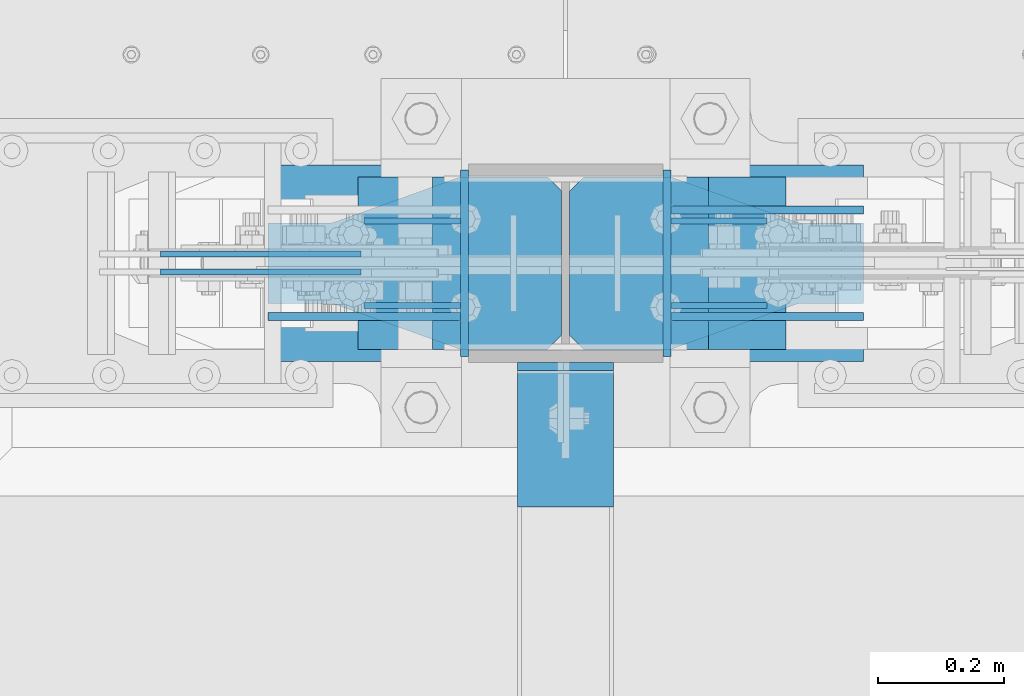
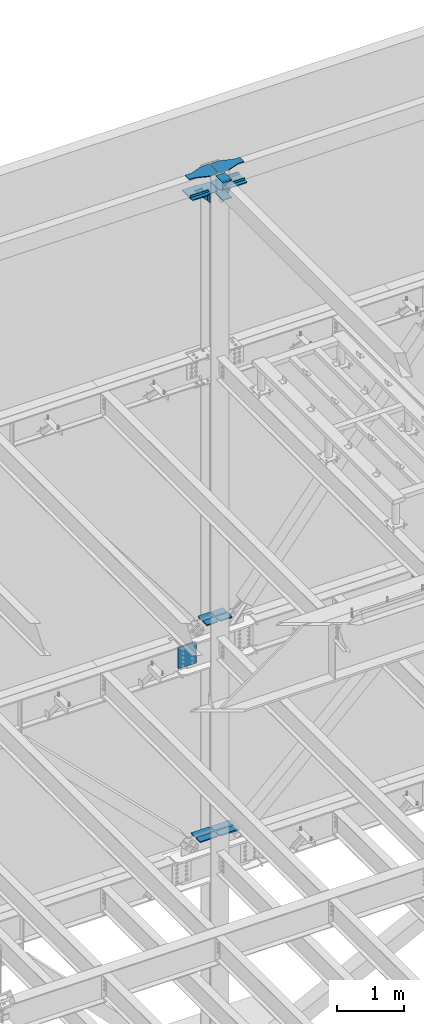
# One storey, part 885 of 1179: 25 beams, 9 elements without a shape of their own.
"""IFC2X3 building model written with IfcOpenShell, lengths in millimetres."""

from ifc_helpers import new_model, si_unit, frame, origin_with_axes, place, context, subcontext, project, spatial, faceted_brep, material, type_object, element, aggregate, save


model = new_model("IFC2X3")

# Units and contexts
model_context = context("Model", 3, precision=1e-05, world=origin_with_axes())
body_context = subcontext(model_context, "Body", "Model", "MODEL_VIEW")
ifc_project = project(units=[si_unit("LENGTHUNIT", "METRE", prefix="MILLI"), si_unit("AREAUNIT", "SQUARE_METRE"), si_unit("VOLUMEUNIT", "CUBIC_METRE"), si_unit("MASSUNIT", "GRAM", prefix="KILO"), si_unit("TIMEUNIT", "SECOND"), si_unit("PLANEANGLEUNIT", "RADIAN"), si_unit("SOLIDANGLEUNIT", "STERADIAN"), si_unit("THERMODYNAMICTEMPERATUREUNIT", "DEGREE_CELSIUS"), si_unit("LUMINOUSINTENSITYUNIT", "LUMEN")], contexts=[model_context])

# Site, building, storey
site_placement = place(None, origin_with_axes())
site = spatial("IfcSite", under=ifc_project, at=site_placement, CompositionType="ELEMENT")
building_placement = place(site_placement, origin_with_axes())
building = spatial("IfcBuilding", under=site, at=building_placement, Name="Undefined", CompositionType="ELEMENT")
storey_placement = place(building_placement, origin_with_axes())
storey = spatial("IfcBuildingStorey", under=building, at=storey_placement, Name="Undefined", CompositionType="ELEMENT", Elevation=0.0)

# Assembly, beams
assembly_1_placement = place(storey_placement, origin_with_axes())
assembly_1 = element("IfcElementAssembly", 1, at=assembly_1_placement, inside=storey, Name="COLUMN", AssemblyPlace="NOTDEFINED", PredefinedType="RIGID_FRAME")
ifc_material_1 = material(Name="STEEL/A36")
beam_type_1 = type_object("IfcBeamType", PredefinedType="NOTDEFINED")
beam_1_placement = place(assembly_1_placement, frame((8120.0625, 41346.4375, 16030.575), z_axis=(0.0, 0.0, 1.0), x_axis=(0.0, -1.0, 0.0)))
beam_1 = element("IfcBeam", 2, at=beam_1_placement, type_object=beam_type_1, material=ifc_material_1, Name="PLATE", context=body_context, shape_type="Brep", body=[
    faceted_brep([(-7.27595761418343e-12, 6.35000000000036, -76.1999999999971), (0.0, 6.35000000000036, 76.2000000000044), (295.274999999994, 6.34999999999854, 76.2000000000007), (295.274999999994, 6.34999999999854, -76.2000000000007), (0.0, -6.35000000000036, 76.2000000000044), (295.274999999994, -6.34999999999854, 76.2000000000007), (7.27595761418343e-12, -6.35000000000036, -76.1999999999971), (295.274999999994, -6.34999999999854, -76.2000000000007)], [[[0, 1, 2, 3]], [[1, 4, 5, 2]], [[4, 6, 7, 5]], [[6, 0, 3, 7]], [[5, 7, 3, 2]], [[6, 4, 1, 0]]]),
])
beam_2_placement = place(assembly_1_placement, frame((8440.73750000001, 41051.1625, 16030.575), z_axis=(0.0, 0.0, 1.0), x_axis=(0.0, 1.0, 0.0)))
beam_2 = element("IfcBeam", 3, at=beam_2_placement, type_object=beam_type_1, material=ifc_material_1, Name="PLATE", context=body_context, shape_type="Brep", body=[
    faceted_brep([(-7.27595761418343e-12, 6.35000000000036, -76.1999999999971), (0.0, 6.35000000000036, 76.2000000000044), (295.274999999994, 6.34999999999854, 76.2000000000007), (295.274999999994, 6.34999999999854, -76.2000000000007), (0.0, -6.35000000000036, 76.2000000000044), (295.274999999994, -6.34999999999854, 76.2000000000007), (7.27595761418343e-12, -6.35000000000036, -76.1999999999971), (295.274999999994, -6.34999999999854, -76.2000000000007)], [[[0, 1, 2, 3]], [[1, 4, 5, 2]], [[4, 6, 7, 5]], [[6, 0, 3, 7]], [[5, 7, 3, 2]], [[6, 4, 1, 0]]]),
])
beam_3_placement = place(assembly_1_placement, frame((8280.4, 40813.0375061035, 16116.3), z_axis=(1.0, 0.0, 0.0), x_axis=(0.0, 1.0, 0.0)))
beam_3 = element("IfcBeam", 4, at=beam_3_placement, type_object=beam_type_1, material=ifc_material_1, Name="PLATE", context=body_context, shape_type="Brep", body=[
    faceted_brep([(215.900000000001, 6.35000000000036, 76.2000000000007), (228.599999999999, -6.35000000000036, 76.2000000000007), (228.599999999999, -6.35000000000036, -76.2000000000007), (215.900000000001, 6.35000000000036, -76.2000000000007), (-7.27595761418343e-12, 6.35000000000036, -76.1999999999971), (0.0, 6.35000000000036, 76.2000000000044), (0.0, -6.35000000000036, 76.2000000000044), (7.27595761418343e-12, -6.35000000000036, -76.1999999999971)], [[[0, 1, 2, 3]], [[4, 5, 0, 3]], [[5, 6, 1, 0]], [[6, 7, 2, 1]], [[7, 4, 3, 2]], [[7, 6, 5, 4]]]),
])
beam_4_placement = place(assembly_1_placement, frame((8280.4, 40813.0375059853, 16435.3875), z_axis=(1.0, 0.0, 0.0), x_axis=(0.0, 1.0, 0.0)))
beam_4 = element("IfcBeam", 5, at=beam_4_placement, type_object=beam_type_1, material=ifc_material_1, Name="PLATE", context=body_context, shape_type="Brep", body=[
    faceted_brep([(215.900000000001, 6.35000000000036, 76.2000000000007), (228.599999999999, -6.35000000000036, 76.2000000000007), (228.599999999999, -6.35000000000036, -76.2000000000007), (215.900000000001, 6.35000000000036, -76.2000000000007), (-7.27595761418343e-12, 6.35000000000036, -76.1999999999971), (0.0, 6.35000000000036, 76.2000000000044), (0.0, -6.35000000000036, 76.2000000000044), (7.27595761418343e-12, -6.35000000000036, -76.1999999999971)], [[[0, 1, 2, 3]], [[4, 5, 0, 3]], [[5, 6, 1, 0]], [[6, 7, 2, 1]], [[7, 4, 3, 2]], [[7, 6, 5, 4]]]),
])

# Assembly, beam
assembly_2_placement = place(storey_placement, origin_with_axes())
assembly_2 = element("IfcElementAssembly", 6, at=assembly_2_placement, inside=storey, Name="PLATE", AssemblyPlace="NOTDEFINED", PredefinedType="RIGID_FRAME")
ifc_material_2 = material(Name="STEEL/A572-GR.50")
beam_type_2 = type_object("IfcBeamType", PredefinedType="NOTDEFINED")
beam_5_placement = place(assembly_2_placement, frame((8274.0300674267, 41124.981, 4351.42154734331), z_axis=(0.0, 1.0, 0.0), x_axis=(-1.0, 0.0, 0.0)))
beam_5 = element("IfcBeam", 7, at=beam_5_placement, type_object=beam_type_2, material=ifc_material_2, Name="PLATE", context=body_context, shape_type="Brep", body=[
    faceted_brep([(0.0, 9.52499999999964, -40.4814999999999), (22.2249999999985, 9.52499999999964, -62.7065000000002), (22.2249999999985, -9.52499999999964, -62.7065000000002), (0.0, -9.52499999999964, -40.4814999999999), (0.0, 9.52499999999964, 62.7065000000002), (322.216540172532, 9.52499999999964, 62.7065000000002), (322.216540172532, 9.52499999999964, -62.7065000000002), (0.0, -9.52499999999964, 62.7065000000002), (322.216540172532, -9.52499999999964, 62.7065000000002), (322.216540172532, -9.52499999999964, -62.7065000000002)], [[[0, 1, 2, 3]], [[4, 5, 6, 1, 0]], [[4, 7, 8, 5]], [[9, 8, 7, 3, 2]], [[6, 9, 2, 1]], [[8, 9, 6, 5]], [[7, 4, 0, 3]]]),
])
aggregate(assembly_2, [beam_5])

assembly_3_placement = place(storey_placement, origin_with_axes())
assembly_3 = element("IfcElementAssembly", 8, at=assembly_3_placement, inside=storey, Name="PLATE", AssemblyPlace="NOTDEFINED", PredefinedType="RIGID_FRAME")
beam_6_placement = place(assembly_3_placement, frame((8274.0300674267, 41272.619, 4351.42154734331), z_axis=(0.0, -1.0, 0.0), x_axis=(-1.0, 0.0, 0.0)))
beam_6 = element("IfcBeam", 9, at=beam_6_placement, type_object=beam_type_2, material=ifc_material_2, Name="PLATE", context=body_context, shape_type="Brep", body=[
    faceted_brep([(0.0, 9.52499999999964, -40.4814999999999), (22.2249999999985, 9.52499999999964, -62.7065000000002), (22.2249999999985, -9.52499999999964, -62.7065000000002), (0.0, -9.52499999999964, -40.4814999999999), (0.0, 9.52499999999964, 62.7065000000002), (322.216540172532, 9.52499999999964, 62.7065000000002), (322.216540172532, 9.52499999999964, -62.7065000000002), (0.0, -9.52499999999964, 62.7065000000002), (322.216540172532, -9.52499999999964, 62.7065000000002), (322.216540172532, -9.52499999999964, -62.7065000000002)], [[[0, 1, 2, 3]], [[4, 5, 6, 1, 0]], [[4, 7, 8, 5]], [[9, 8, 7, 3, 2]], [[6, 9, 2, 1]], [[8, 9, 6, 5]], [[7, 4, 0, 3]]]),
])
aggregate(assembly_3, [beam_6])

# Beam
beam_type_3 = type_object("IfcBeamType", PredefinedType="NOTDEFINED")
beam_7_placement = place(assembly_1_placement, frame((8286.75, 41125.775, 8263.92332782742), z_axis=(0.0, -1.0, 0.0), x_axis=(1.0, 0.0, 0.0)))
beam_7 = element("IfcBeam", 10, at=beam_7_placement, type_object=beam_type_3, material=ifc_material_2, Name="PLATE", context=body_context, shape_type="Brep", body=[
    faceted_brep([(1.81898940354586e-11, -9.52499999999782, 41.2750000000015), (22.2250000000204, -9.525000000006, 63.5), (22.2249999999913, 9.52499999999327, 63.5), (-7.27595761418343e-12, 9.52500000000146, 41.2750000000015), (220.259323929029, 9.52499999999964, 63.5), (220.259325144028, 9.52499999999964, -63.5), (0.0, 9.52500000000146, -63.5), (220.259323929029, -9.52499999999964, 63.5), (0.0, -9.52500000000146, -63.5), (220.259325144028, -9.52499999999964, -63.5)], [[[0, 1, 2, 3]], [[4, 5, 6, 3, 2]], [[7, 4, 2, 1]], [[8, 9, 7, 1, 0]], [[8, 6, 5, 9]], [[7, 9, 5, 4]], [[6, 8, 0, 3]]]),
])

beam_8_placement = place(assembly_1_placement, frame((8286.75, 41271.825, 8263.92332782742), z_axis=(0.0, 1.0, 0.0), x_axis=(1.0, 0.0, 0.0)))
beam_8 = element("IfcBeam", 11, at=beam_8_placement, type_object=beam_type_3, material=ifc_material_2, Name="PLATE", context=body_context, shape_type="Brep", body=[
    faceted_brep([(1.81898940354586e-11, -9.52499999999782, 41.2750000000015), (22.2250000000204, -9.525000000006, 63.5), (22.2249999999913, 9.52499999999327, 63.5), (-7.27595761418343e-12, 9.52500000000146, 41.2750000000015), (220.259323929029, 9.52499999999964, 63.5), (220.259325144028, 9.52499999999964, -63.5), (0.0, 9.52500000000146, -63.5), (220.259323929029, -9.52499999999964, 63.5), (0.0, -9.52500000000146, -63.5), (220.259325144028, -9.52499999999964, -63.5)], [[[0, 1, 2, 3]], [[4, 5, 6, 3, 2]], [[7, 4, 2, 1]], [[8, 9, 7, 1, 0]], [[8, 6, 5, 9]], [[7, 9, 5, 4]], [[6, 8, 0, 3]]]),
])

beam_9_placement = place(assembly_1_placement, frame((8069.89870376747, 41125.775, 8263.92332782742), z_axis=(0.0, -1.0, 0.0), x_axis=(1.0, 0.0, 0.0)))
beam_9 = element("IfcBeam", 12, at=beam_9_placement, type_object=beam_type_3, material=ifc_material_2, Name="PLATE", context=body_context, shape_type="Brep", body=[
    faceted_brep([(204.151296232532, 9.52499999999964, 41.2750000000015), (181.926296232532, 9.52499999999964, 63.5), (181.926296232532, -9.52499999999964, 63.5), (204.151296232532, -9.52499999999964, 41.2750000000015), (204.151296232532, 9.52499999999964, -63.5), (0.0, 9.52500000000146, -63.5), (0.0, 9.52500000000146, 63.5), (0.0, -9.52500000000146, 63.5), (0.0, -9.52500000000146, -63.5), (204.151296232532, -9.52499999999964, -63.5)], [[[0, 1, 2, 3]], [[4, 5, 6, 1, 0]], [[6, 7, 2, 1]], [[7, 8, 9, 3, 2]], [[8, 5, 4, 9]], [[9, 4, 0, 3]], [[8, 7, 6, 5]]]),
])

beam_10_placement = place(assembly_1_placement, frame((8069.89870376747, 41271.825, 8263.92332782742), z_axis=(0.0, 1.0, 0.0), x_axis=(1.0, 0.0, 0.0)))
beam_10 = element("IfcBeam", 13, at=beam_10_placement, type_object=beam_type_3, material=ifc_material_2, Name="PLATE", context=body_context, shape_type="Brep", body=[
    faceted_brep([(204.151296232532, 9.52499999999964, 41.2750000000015), (181.926296232532, 9.52499999999964, 63.5), (181.926296232532, -9.52499999999964, 63.5), (204.151296232532, -9.52499999999964, 41.2750000000015), (204.151296232532, 9.52499999999964, -63.5), (0.0, 9.52500000000146, -63.5), (0.0, 9.52500000000146, 63.5), (0.0, -9.52500000000146, 63.5), (0.0, -9.52500000000146, -63.5), (204.151296232532, -9.52499999999964, -63.5)], [[[0, 1, 2, 3]], [[4, 5, 6, 1, 0]], [[6, 7, 2, 1]], [[7, 8, 9, 3, 2]], [[8, 5, 4, 9]], [[9, 4, 0, 3]], [[8, 7, 6, 5]]]),
])

# Assembly, beam
assembly_4_placement = place(storey_placement, origin_with_axes())
assembly_4 = element("IfcElementAssembly", 14, at=assembly_4_placement, inside=storey, Name="PLATE", AssemblyPlace="NOTDEFINED", PredefinedType="RIGID_FRAME")
beam_type_4 = type_object("IfcBeamType", PredefinedType="NOTDEFINED")
beam_11_placement = place(assembly_4_placement, frame((8286.75, 41123.3935, 4348.24654734331), z_axis=(0.0, 1.0, 0.0), x_axis=(1.0, 0.0, 0.0)))
beam_11 = element("IfcBeam", 15, at=beam_11_placement, type_object=beam_type_4, material=ifc_material_2, Name="PLATE", context=body_context, shape_type="Brep", body=[
    faceted_brep([(22.2249999999985, -12.6999999999998, -61.1189999999997), (0.0, -12.6999999999998, -38.8940000000002), (0.0, 12.6999999999998, -38.8940000000002), (22.2249999999985, 12.6999999999998, -61.1189999999997), (0.0, 12.7, 61.1189999999988), (342.342939159009, 12.6999999999998, 61.1189999999988), (342.342939159009, 12.6999999999998, -61.1189999999988), (0.0, -12.7, 61.1189999999988), (342.342939159009, -12.6999999999998, 61.1189999999988), (342.342939159009, -12.6999999999998, -61.1189999999988)], [[[0, 1, 2, 3]], [[4, 5, 6, 3, 2]], [[4, 7, 8, 5]], [[9, 8, 7, 1, 0]], [[6, 9, 0, 3]], [[8, 9, 6, 5]], [[7, 4, 2, 1]]]),
])
aggregate(assembly_4, [beam_11])

assembly_5_placement = place(storey_placement, origin_with_axes())
assembly_5 = element("IfcElementAssembly", 16, at=assembly_5_placement, inside=storey, Name="PLATE", AssemblyPlace="NOTDEFINED", PredefinedType="RIGID_FRAME")
beam_12_placement = place(assembly_5_placement, frame((8286.75, 41274.2065, 4348.24654734331), z_axis=(0.0, -1.0, 0.0), x_axis=(1.0, 0.0, 0.0)))
beam_12 = element("IfcBeam", 17, at=beam_12_placement, type_object=beam_type_4, material=ifc_material_2, Name="PLATE", context=body_context, shape_type="Brep", body=[
    faceted_brep([(22.2249999999985, -12.6999999999998, -61.1189999999997), (0.0, -12.6999999999998, -38.8940000000002), (0.0, 12.6999999999998, -38.8940000000002), (22.2249999999985, 12.6999999999998, -61.1189999999997), (0.0, 12.7, 61.1189999999988), (342.342939159009, 12.6999999999998, 61.1189999999988), (342.342939159009, 12.6999999999998, -61.1189999999988), (0.0, -12.7, 61.1189999999988), (342.342939159009, -12.6999999999998, 61.1189999999988), (342.342939159009, -12.6999999999998, -61.1189999999988)], [[[0, 1, 2, 3]], [[4, 5, 6, 3, 2]], [[4, 7, 8, 5]], [[9, 8, 7, 1, 0]], [[6, 9, 0, 3]], [[8, 9, 6, 5]], [[7, 4, 2, 1]]]),
])
aggregate(assembly_5, [beam_12])

# Beam
beam_type_5 = type_object("IfcBeamType", PredefinedType="NOTDEFINED")
beam_13_placement = place(assembly_1_placement, frame((7808.91249948694, 41114.6625, 16141.7), z_axis=(0.0, 0.0, 1.0), x_axis=(1.0, 0.0, 0.0)))
beam_13 = element("IfcBeam", 18, at=beam_13_placement, type_object=beam_type_5, material=ifc_material_1, Name="PLATE", context=body_context, shape_type="Brep", body=[
    faceted_brep([(0.0, 6.34999999999854, -19.0499999999993), (0.0, 6.35000000000036, 19.0499999999993), (317.5, 6.34999999999854, 19.0499999999993), (317.5, 6.34999999999854, -19.0499999999993), (0.0, -6.35000000000036, 19.0499999999993), (317.5, -6.34999999999854, 19.0499999999993), (0.0, -6.34999999999854, -19.0499999999993), (317.5, -6.34999999999854, -19.0499999999993)], [[[0, 1, 2, 3]], [[1, 4, 5, 2]], [[4, 6, 7, 5]], [[6, 0, 3, 7]], [[5, 7, 3, 2]], [[6, 4, 1, 0]]]),
])

beam_14_placement = place(assembly_1_placement, frame((8751.88749948694, 41114.6625, 16141.7), z_axis=(0.0, 0.0, 1.0), x_axis=(-1.0, 0.0, 0.0)))
beam_14 = element("IfcBeam", 19, at=beam_14_placement, type_object=beam_type_5, material=ifc_material_1, Name="PLATE", context=body_context, shape_type="Brep", body=[
    faceted_brep([(0.0, 6.34999999999854, -19.0499999999993), (0.0, 6.35000000000036, 19.0499999999993), (317.5, 6.34999999999854, 19.0499999999993), (317.5, 6.34999999999854, -19.0499999999993), (0.0, -6.35000000000036, 19.0499999999993), (317.5, -6.34999999999854, 19.0499999999993), (0.0, -6.34999999999854, -19.0499999999993), (317.5, -6.34999999999854, -19.0499999999993)], [[[0, 1, 2, 3]], [[1, 4, 5, 2]], [[4, 6, 7, 5]], [[6, 0, 3, 7]], [[5, 7, 3, 2]], [[6, 4, 1, 0]]]),
])

beam_15_placement = place(assembly_1_placement, frame((8751.8875, 41282.9375, 16141.7), z_axis=(0.0, 0.0, 1.0), x_axis=(-1.0, 0.0, 0.0)))
beam_15 = element("IfcBeam", 20, at=beam_15_placement, type_object=beam_type_5, material=ifc_material_1, Name="PLATE", context=body_context, shape_type="Brep", body=[
    faceted_brep([(0.0, 6.34999999999854, -19.0499999999993), (0.0, 6.35000000000036, 19.0499999999993), (317.5, 6.34999999999854, 19.0499999999993), (317.5, 6.34999999999854, -19.0499999999993), (0.0, -6.35000000000036, 19.0499999999993), (317.5, -6.34999999999854, 19.0499999999993), (0.0, -6.34999999999854, -19.0499999999993), (317.5, -6.34999999999854, -19.0499999999993)], [[[0, 1, 2, 3]], [[1, 4, 5, 2]], [[4, 6, 7, 5]], [[6, 0, 3, 7]], [[5, 7, 3, 2]], [[6, 4, 1, 0]]]),
])

beam_type_6 = type_object("IfcBeamType", PredefinedType="NOTDEFINED")
beam_16_placement = place(assembly_1_placement, frame((7961.31249897387, 41265.475, 16030.575), z_axis=(0.0, 0.0, 1.0), x_axis=(1.0, 0.0, 0.0)))
beam_16 = element("IfcBeam", 21, at=beam_16_placement, type_object=beam_type_6, material=ifc_material_1, Name="PLATE", context=body_context, shape_type="Brep", body=[
    faceted_brep([(152.4, -4.76249999999709, 76.2), (152.4, -4.76249999999709, -76.2), (152.4, 4.76249999999709, -76.2), (152.4, 4.76249999999709, 76.2), (0.0, 4.76249999999982, 76.1999999999971), (0.0, -4.76249999999982, 76.1999999999971)], [[[0, 1, 2, 3]], [[3, 2, 4]], [[4, 5, 0, 3]], [[0, 5, 1]], [[4, 2, 1, 5]]]),
])

beam_17_placement = place(assembly_1_placement, frame((7961.31249897387, 41132.125, 16030.575), z_axis=(0.0, 0.0, 1.0), x_axis=(1.0, 0.0, 0.0)))
beam_17 = element("IfcBeam", 22, at=beam_17_placement, type_object=beam_type_6, material=ifc_material_1, Name="PLATE", context=body_context, shape_type="Brep", body=[
    faceted_brep([(152.4, -4.76249999999709, 76.2), (152.4, -4.76249999999709, -76.2), (152.4, 4.76249999999709, -76.2), (152.4, 4.76249999999709, 76.2), (0.0, 4.76249999999982, 76.1999999999971), (0.0, -4.76249999999982, 76.1999999999971)], [[[0, 1, 2, 3]], [[3, 2, 4]], [[4, 5, 0, 3]], [[0, 5, 1]], [[4, 2, 1, 5]]]),
])

beam_18_placement = place(assembly_1_placement, frame((8599.48750000001, 41132.125, 16030.575), z_axis=(0.0, 0.0, 1.0), x_axis=(-1.0, 0.0, 0.0)))
beam_18 = element("IfcBeam", 23, at=beam_18_placement, type_object=beam_type_6, material=ifc_material_1, Name="PLATE", context=body_context, shape_type="Brep", body=[
    faceted_brep([(152.4, -4.76249999999709, 76.2), (152.4, -4.76249999999709, -76.2), (152.4, 4.76249999999709, -76.2), (152.4, 4.76249999999709, 76.2), (0.0, 4.76249999999982, 76.1999999999971), (0.0, -4.76249999999982, 76.1999999999971)], [[[0, 1, 2, 3]], [[3, 2, 4]], [[4, 5, 0, 3]], [[0, 5, 1]], [[4, 2, 1, 5]]]),
])

beam_19_placement = place(assembly_1_placement, frame((8599.48750000001, 41265.475, 16030.575), z_axis=(0.0, 0.0, 1.0), x_axis=(-1.0, 0.0, 0.0)))
beam_19 = element("IfcBeam", 24, at=beam_19_placement, type_object=beam_type_6, material=ifc_material_1, Name="PLATE", context=body_context, shape_type="Brep", body=[
    faceted_brep([(152.4, -4.76249999999709, 76.2), (152.4, -4.76249999999709, -76.2), (152.4, 4.76249999999709, -76.2), (152.4, 4.76249999999709, 76.2), (0.0, 4.76249999999982, 76.1999999999971), (0.0, -4.76249999999982, 76.1999999999971)], [[[0, 1, 2, 3]], [[3, 2, 4]], [[4, 5, 0, 3]], [[0, 5, 1]], [[4, 2, 1, 5]]]),
])

beam_type_7 = type_object("IfcBeamType", PredefinedType="NOTDEFINED")
beam_20_placement = place(assembly_1_placement, frame((7808.91249897387, 41198.8, 16114.7125), z_axis=(0.0, -1.0, 0.0), x_axis=(1.0, 0.0, 0.0)))
beam_20 = element("IfcBeam", 25, at=beam_20_placement, type_object=beam_type_7, material=ifc_material_1, Name="PLATE", context=body_context, shape_type="Brep", body=[
    faceted_brep([(465.137499999997, -7.9375, -114.300000762945), (442.912499999999, -7.9375, -136.525000762944), (442.912500000006, 7.9375, -136.525000762944), (465.137500000004, 7.9375, -114.300000762945), (465.137500000004, 7.9375, 114.300000762938), (442.912500000006, 7.9375, 136.525000762937), (442.912499999999, -7.9375, 136.525000762937), (465.137499999997, -7.9375, 114.300000762938), (241.300006103491, -7.9375, -155.575000000001), (241.300006103491, 7.9375, -155.575000000001), (304.799990844724, 7.9375, -136.525000762944), (304.799990844724, -7.9375, -136.525000762944), (0.0, -7.9375, -155.575000000001), (0.0, -7.9375, 155.575000000001), (0.0, 7.9375, 155.575000000001), (0.0, 7.9375, -155.575000000001), (241.300006103513, -7.9375, 155.575000000001), (241.300006103513, 7.9375, 155.575000000001), (304.799990844724, -7.9375, 136.525000762937), (304.799990844724, 7.9375, 136.525000762937)], [[[0, 1, 2, 3]], [[4, 5, 6, 7]], [[8, 9, 10, 11]], [[11, 10, 2, 1]], [[12, 13, 14, 15]], [[14, 13, 16, 17]], [[18, 19, 17, 16]], [[19, 18, 6, 5]], [[4, 7, 0, 3]], [[10, 9, 15, 14, 17, 19, 5, 4, 3, 2]], [[12, 15, 9, 8]], [[7, 6, 18, 16, 13, 12, 8, 11, 1, 0]]]),
])

beam_21_placement = place(assembly_1_placement, frame((8751.8875, 41198.8, 16114.7125), z_axis=(0.0, 1.0, 0.0), x_axis=(-1.0, 0.0, 0.0)))
beam_21 = element("IfcBeam", 26, at=beam_21_placement, type_object=beam_type_7, material=ifc_material_1, Name="PLATE", context=body_context, shape_type="Brep", body=[
    faceted_brep([(465.137499999997, -7.9375, -114.300000762945), (442.912499999999, -7.9375, -136.525000762944), (442.912500000006, 7.9375, -136.525000762944), (465.137500000004, 7.9375, -114.300000762945), (465.137500000004, 7.9375, 114.300000762938), (442.912500000006, 7.9375, 136.525000762937), (442.912499999999, -7.9375, 136.525000762937), (465.137499999997, -7.9375, 114.300000762938), (241.300006103491, -7.9375, -155.575000000001), (241.300006103491, 7.9375, -155.575000000001), (304.799990844724, 7.9375, -136.525000762944), (304.799990844724, -7.9375, -136.525000762944), (0.0, -7.9375, -155.575000000001), (0.0, -7.9375, 155.575000000001), (0.0, 7.9375, 155.575000000001), (0.0, 7.9375, -155.575000000001), (241.300006103513, -7.9375, 155.575000000001), (241.300006103513, 7.9375, 155.575000000001), (304.799990844724, -7.9375, 136.525000762937), (304.799990844724, 7.9375, 136.525000762937)], [[[0, 1, 2, 3]], [[4, 5, 6, 7]], [[8, 9, 10, 11]], [[11, 10, 2, 1]], [[12, 13, 14, 15]], [[14, 13, 16, 17]], [[18, 19, 17, 16]], [[19, 18, 6, 5]], [[4, 7, 0, 3]], [[10, 9, 15, 14, 17, 19, 5, 4, 3, 2]], [[12, 15, 9, 8]], [[7, 6, 18, 16, 13, 12, 8, 11, 1, 0]]]),
])

aggregate(assembly_1, [beam_16, beam_13, beam_17, beam_20, beam_1, beam_14, beam_18, beam_15, beam_19, beam_21, beam_2, beam_3, beam_4, beam_7, beam_8, beam_9, beam_10])

# Assembly, beam
assembly_6_placement = place(storey_placement, origin_with_axes())
assembly_6 = element("IfcElementAssembly", 27, at=assembly_6_placement, inside=storey, Name="PLATE", AssemblyPlace="NOTDEFINED", PredefinedType="RIGID_FRAME")
beam_type_8 = type_object("IfcBeamType", PredefinedType="NOTDEFINED")
beam_22_placement = place(assembly_6_placement, frame((7808.91249897387, 41198.8, 16435.3875), z_axis=(0.0, -1.0, 0.0), x_axis=(1.0, 0.0, 0.0)))
beam_22 = element("IfcBeam", 28, at=beam_22_placement, type_object=beam_type_8, material=ifc_material_1, Name="PLATE", context=body_context, shape_type="Brep", body=[
    faceted_brep([(465.137499999997, -7.9375, -114.300000762945), (442.912499999999, -7.9375, -136.525000762944), (442.912500000006, 7.9375, -136.525000762944), (465.137500000004, 7.9375, -114.300000762945), (465.137500000004, 7.9375, 114.300000762938), (442.912500000006, 7.9375, 136.525000762937), (442.912499999999, -7.9375, 136.525000762937), (465.137499999997, -7.9375, 114.300000762938), (97.1744871646697, -7.9375, 63.4999984741225), (97.1744871646697, 7.9375, 63.4999984741225), (0.0, 7.9375, 63.5), (0.0, -7.9375, 63.5), (99.3625358760146, -7.9375, 63.5944172169256), (99.3625358760146, 7.9375, 63.5944172169256), (101.534317436837, -7.9375, 63.8769714847585), (101.534317436837, 7.9375, 63.8769714847585), (103.673685635511, -7.9375, 64.3455606147181), (103.673685635511, 7.9375, 64.3455606147181), (105.764735239063, -7.9375, 64.9967008589738), (105.764735239063, 7.9375, 64.9967008589738), (304.799990844724, -7.9375, 136.525000762937), (304.799990844724, 7.9375, 136.525000762937), (0.0, -7.9375, -63.5), (0.0, 7.9375, -63.5), (97.1744871646697, 7.9375, -63.5), (97.1744871646697, -7.9375, -63.5), (99.3625358760146, 7.9375, -63.5944187428031), (99.3625358760146, -7.9375, -63.5944187428031), (101.534317436837, 7.9375, -63.876973010636), (101.534317436837, -7.9375, -63.876973010636), (103.673685635511, 7.9375, -64.3455621405956), (103.673685635511, -7.9375, -64.3455621405956), (105.764735239063, 7.9375, -64.9967023848512), (105.764735239063, -7.9375, -64.9967023848512), (304.799990844724, -7.9375, -136.525000762944), (304.799990844724, 7.9375, -136.525000762944)], [[[0, 1, 2, 3]], [[4, 5, 6, 7]], [[8, 9, 10, 11]], [[12, 13, 9, 8]], [[14, 15, 13, 12]], [[16, 17, 15, 14]], [[18, 19, 17, 16]], [[20, 21, 19, 18]], [[22, 23, 24, 25]], [[25, 24, 26, 27]], [[27, 26, 28, 29]], [[29, 28, 30, 31]], [[31, 30, 32, 33]], [[34, 33, 32, 35]], [[34, 35, 2, 1]], [[4, 7, 0, 3]], [[7, 6, 20, 18, 16, 14, 12, 8, 11, 22, 25, 27, 29, 31, 33, 34, 1, 0]], [[22, 11, 10, 23]], [[35, 32, 30, 28, 26, 24, 23, 10, 9, 13, 15, 17, 19, 21, 5, 4, 3, 2]], [[21, 20, 6, 5]]]),
])
aggregate(assembly_6, [beam_22])

assembly_7_placement = place(storey_placement, origin_with_axes())
assembly_7 = element("IfcElementAssembly", 29, at=assembly_7_placement, inside=storey, Name="PLATE", AssemblyPlace="NOTDEFINED", PredefinedType="RIGID_FRAME")
beam_23_placement = place(assembly_7_placement, frame((8751.8875, 41198.8, 16435.3875), z_axis=(0.0, 1.0, 0.0), x_axis=(-1.0, 0.0, 0.0)))
beam_23 = element("IfcBeam", 30, at=beam_23_placement, type_object=beam_type_8, material=ifc_material_1, Name="PLATE", context=body_context, shape_type="Brep", body=[
    faceted_brep([(465.137499999997, -7.9375, -114.300000762945), (442.912499999999, -7.9375, -136.525000762944), (442.912500000006, 7.9375, -136.525000762944), (465.137500000004, 7.9375, -114.300000762945), (465.137500000004, 7.9375, 114.300000762938), (442.912500000006, 7.9375, 136.525000762937), (442.912499999999, -7.9375, 136.525000762937), (465.137499999997, -7.9375, 114.300000762938), (97.1744871646697, -7.9375, 63.4999984741225), (97.1744871646697, 7.9375, 63.4999984741225), (0.0, 7.9375, 63.5), (0.0, -7.9375, 63.5), (99.3625358760146, -7.9375, 63.5944172169256), (99.3625358760146, 7.9375, 63.5944172169256), (101.534317436837, -7.9375, 63.8769714847585), (101.534317436837, 7.9375, 63.8769714847585), (103.673685635511, -7.9375, 64.3455606147181), (103.673685635511, 7.9375, 64.3455606147181), (105.764735239063, -7.9375, 64.9967008589738), (105.764735239063, 7.9375, 64.9967008589738), (304.799990844724, -7.9375, 136.525000762937), (304.799990844724, 7.9375, 136.525000762937), (0.0, -7.9375, -63.5), (0.0, 7.9375, -63.5), (97.1744871646697, 7.9375, -63.5), (97.1744871646697, -7.9375, -63.5), (99.3625358760146, 7.9375, -63.5944187428031), (99.3625358760146, -7.9375, -63.5944187428031), (101.534317436837, 7.9375, -63.876973010636), (101.534317436837, -7.9375, -63.876973010636), (103.673685635511, 7.9375, -64.3455621405956), (103.673685635511, -7.9375, -64.3455621405956), (105.764735239063, 7.9375, -64.9967023848512), (105.764735239063, -7.9375, -64.9967023848512), (304.799990844724, -7.9375, -136.525000762944), (304.799990844724, 7.9375, -136.525000762944)], [[[0, 1, 2, 3]], [[4, 5, 6, 7]], [[8, 9, 10, 11]], [[12, 13, 9, 8]], [[14, 15, 13, 12]], [[16, 17, 15, 14]], [[18, 19, 17, 16]], [[20, 21, 19, 18]], [[22, 23, 24, 25]], [[25, 24, 26, 27]], [[27, 26, 28, 29]], [[29, 28, 30, 31]], [[31, 30, 32, 33]], [[34, 33, 32, 35]], [[34, 35, 2, 1]], [[4, 7, 0, 3]], [[7, 6, 20, 18, 16, 14, 12, 8, 11, 22, 25, 27, 29, 31, 33, 34, 1, 0]], [[22, 11, 10, 23]], [[35, 32, 30, 28, 26, 24, 23, 10, 9, 13, 15, 17, 19, 21, 5, 4, 3, 2]], [[21, 20, 6, 5]]]),
])
aggregate(assembly_7, [beam_23])

assembly_8_placement = place(storey_placement, origin_with_axes())
assembly_8 = element("IfcElementAssembly", 31, at=assembly_8_placement, inside=storey, Name="PLATE", AssemblyPlace="NOTDEFINED", PredefinedType="RIGID_FRAME")
beam_type_9 = type_object("IfcBeamType", PredefinedType="NOTDEFINED")
beam_24_placement = place(assembly_8_placement, frame((7639.24021325796, 41213.0872136118, 7739.06186150222), z_axis=(0.0, 0.0, -1.0), x_axis=(1.0, 0.0, 0.0)))
beam_24 = element("IfcBeam", 32, at=beam_24_placement, type_object=beam_type_9, material=ifc_material_2, Name="PLATE", context=body_context, shape_type="Brep", body=[
    faceted_brep([(0.0, 4.76249999999709, -190.5), (0.0, 4.76249999999709, 190.5), (317.499999999995, 4.76250000000073, 190.500000000051), (317.500000000042, 4.76250000000073, -190.499999999973), (0.0, -4.76249999999709, 190.5), (317.499999999995, -4.76250000000073, 190.500000000051), (0.0, -4.76249999999709, -190.5), (317.500000000042, -4.76250000000073, -190.499999999973)], [[[0, 1, 2, 3]], [[1, 4, 5, 2]], [[4, 6, 7, 5]], [[6, 0, 3, 7]], [[5, 7, 3, 2]], [[6, 4, 1, 0]]]),
])
aggregate(assembly_8, [beam_24])

assembly_9_placement = place(storey_placement, origin_with_axes())
assembly_9 = element("IfcElementAssembly", 33, at=assembly_9_placement, inside=storey, Name="PLATE", AssemblyPlace="NOTDEFINED", PredefinedType="RIGID_FRAME")
beam_25_placement = place(assembly_9_placement, frame((7956.74010197833, 41184.5127863882, 7739.05987843069), z_axis=(0.0, 0.0, -1.0), x_axis=(-1.0, 0.0, 0.0)))
beam_25 = element("IfcBeam", 34, at=beam_25_placement, type_object=beam_type_9, material=ifc_material_2, Name="PLATE", context=body_context, shape_type="Brep", body=[
    faceted_brep([(0.0, 4.76249999999709, -190.5), (0.0, 4.76249999999709, 190.5), (317.499999999995, 4.76250000000073, 190.500000000051), (317.500000000042, 4.76250000000073, -190.499999999973), (0.0, -4.76249999999709, 190.5), (317.499999999995, -4.76250000000073, 190.500000000051), (0.0, -4.76249999999709, -190.5), (317.500000000042, -4.76250000000073, -190.499999999973)], [[[0, 1, 2, 3]], [[1, 4, 5, 2]], [[4, 6, 7, 5]], [[6, 0, 3, 7]], [[5, 7, 3, 2]], [[6, 4, 1, 0]]]),
])
aggregate(assembly_9, [beam_25])

save(model, "model.ifc")
